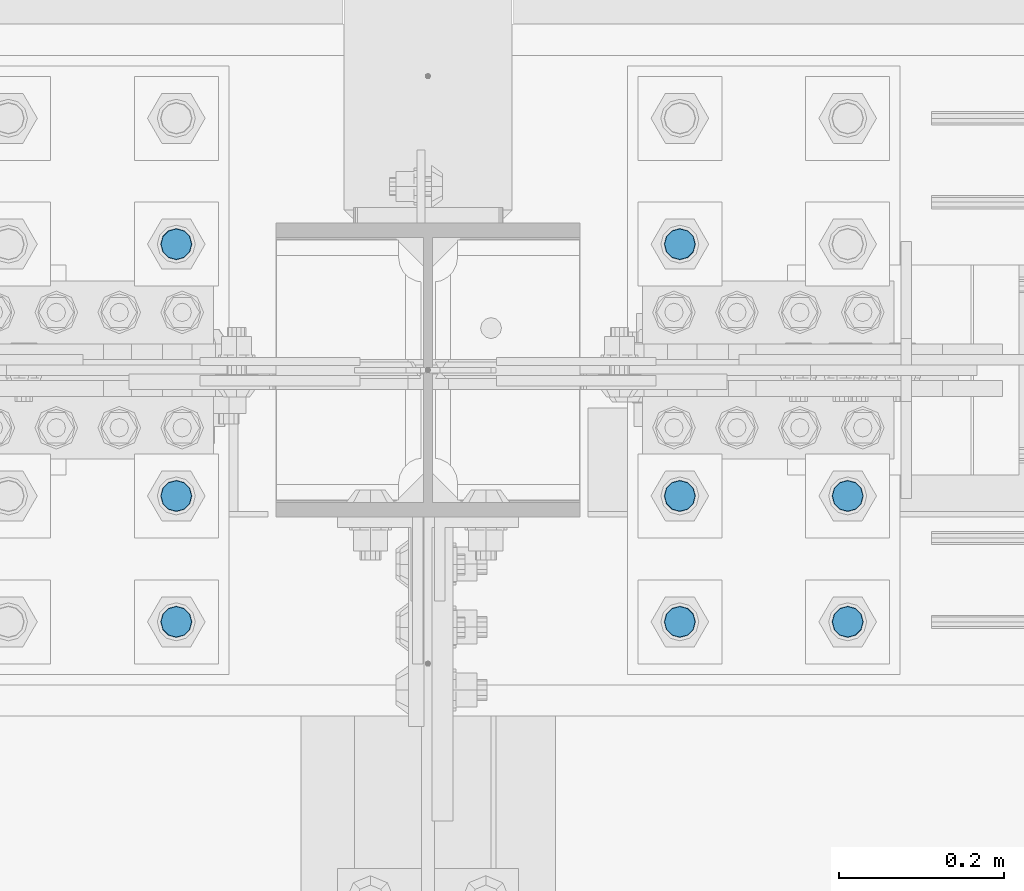
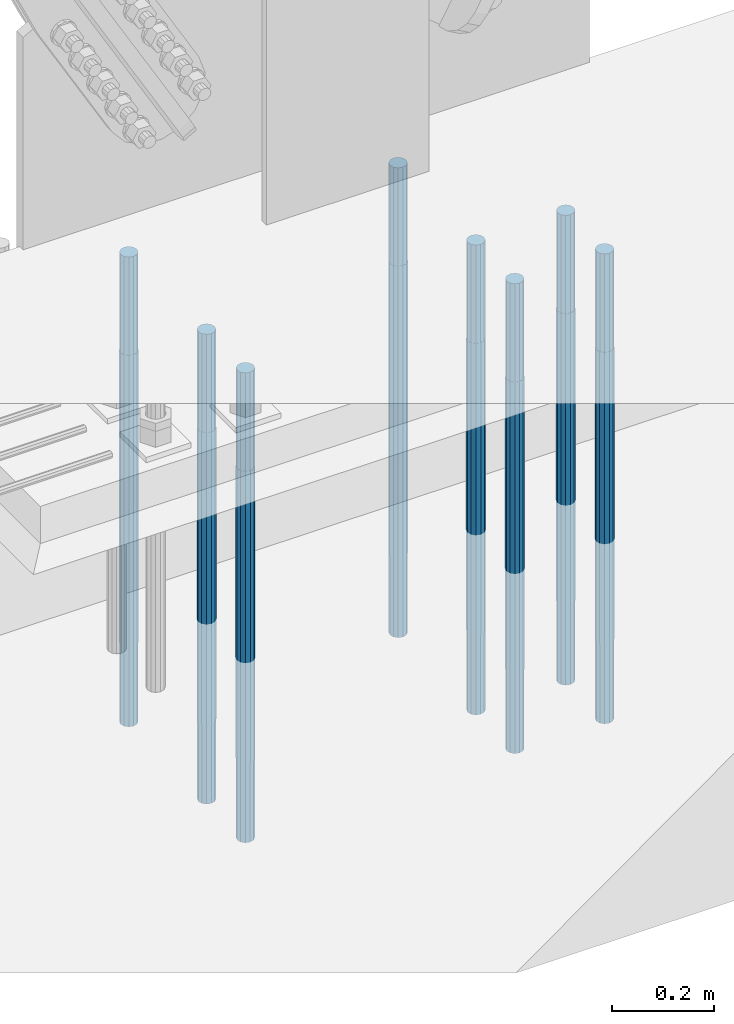
# One storey, part 1382 of 3843: 8 columns, 1 element without a shape of its own.
"""IFC2X3 building model written with IfcOpenShell, lengths in millimetres."""

import ifcopenshell
import ifcopenshell.guid

model = None  # the IFC model being written
_history = None  # IfcOwnerHistory: only IFC2X3 demands one
_inside = {}  # id of a spatial element -> (the spatial element, [elements in it])
_under = {}  # id of a project, library or spatial element -> (it, [spatial elements below it])
_declared = {}  # id of a project -> (the project, [libraries it declares])
_typed = {}  # id of a type object -> (the type object, [elements of that type])
_made_of = {}  # id of a material, layer set ... -> (it, [elements and type objects made of it])


def new_model(schema):
    """Start an empty IFC model of exactly this schema.

    Asked for "IFC4X3", IfcOpenShell would pick the latest addendum, in which some entities
    have other attributes; the version numbers below select the first issue.
    IFC2X3 requires an IfcOwnerHistory on every rooted entity: one is made here for all.
    """
    global model, _history
    if schema == "IFC4X3":
        model = ifcopenshell.file(schema_version=(4, 3, 0, 0))
    else:
        model = ifcopenshell.file(schema=schema)
    _inside.clear()
    _under.clear()
    _declared.clear()
    _typed.clear()
    _made_of.clear()
    _history = None
    if model.schema == "IFC2X3":
        org = make("IfcOrganization", Name="unknown")
        user = make(
            "IfcPersonAndOrganization",
            ThePerson=make("IfcPerson", FamilyName="unknown"),
            TheOrganization=org,
        )
        app = make(
            "IfcApplication",
            ApplicationDeveloper=org,
            Version="unknown",
            ApplicationFullName="unknown",
            ApplicationIdentifier="unknown",
        )
        _history = make(
            "IfcOwnerHistory",
            OwningUser=user,
            OwningApplication=app,
            ChangeAction="ADDED",
            CreationDate=0,
        )
    return model


def make(cls, **values):
    """One entity of the class cls with the attributes given. An attribute that is None is left unset."""
    return model.create_entity(
        cls, **{name: value for name, value in values.items() if value is not None}
    )


def rooted(cls, **values):
    """An entity with a GlobalId (a new one), such as an element, a storey or a relation."""
    return make(cls, GlobalId=ifcopenshell.guid.new(), OwnerHistory=_history, **values)


def si_unit(unit_type, name, prefix=None):
    """IfcSIUnit, for example si_unit("LENGTHUNIT", "METRE", prefix="MILLI")."""
    return make("IfcSIUnit", UnitType=unit_type, Prefix=prefix, Name=name)


def assignment(units):
    """IfcUnitAssignment: the units of a project."""
    return None if units is None else make("IfcUnitAssignment", Units=units)


def point(xyz):
    """IfcCartesianPoint."""
    return None if xyz is None else make("IfcCartesianPoint", Coordinates=xyz)


def direction(xyz):
    """IfcDirection."""
    return None if xyz is None else make("IfcDirection", DirectionRatios=xyz)


def frame(location, z_axis=None, x_axis=None):
    """IfcAxis2Placement3D, a coordinate frame: its origin and axes. An axis left out is left unset."""
    return make(
        "IfcAxis2Placement3D",
        Location=point(location),
        Axis=direction(z_axis),
        RefDirection=direction(x_axis),
    )


def origin_with_axes():
    """The frame at (0, 0, 0) with the z axis (0, 0, 1) and the x axis (1, 0, 0) written out."""
    return frame((0.0, 0.0, 0.0), z_axis=(0.0, 0.0, 1.0), x_axis=(1.0, 0.0, 0.0))


def place(relative_to, where):
    """IfcLocalPlacement: puts the frame where relative to a parent placement (None: the world)."""
    return make(
        "IfcLocalPlacement", PlacementRelTo=relative_to, RelativePlacement=where
    )


def context(
    kind, dimensions, precision=None, world=None, true_north=None, identifier=None
):
    """IfcGeometricRepresentationContext, for example the 3D "Model" context."""
    return make(
        "IfcGeometricRepresentationContext",
        ContextIdentifier=identifier,
        ContextType=kind,
        CoordinateSpaceDimension=dimensions,
        Precision=precision,
        WorldCoordinateSystem=world,
        TrueNorth=true_north,
    )


def subcontext(parent, identifier, kind, view, scale=None):
    """IfcGeometricRepresentationSubContext, for example "Body" below "Model"."""
    return make(
        "IfcGeometricRepresentationSubContext",
        ContextIdentifier=identifier,
        ContextType=kind,
        ParentContext=parent,
        TargetScale=scale,
        TargetView=view,
    )


def project(units=None, contexts=None):
    """IfcProject with its units and contexts."""
    return rooted(
        "IfcProject",
        Name="project",
        RepresentationContexts=contexts,
        UnitsInContext=assignment(units),
    )


def spatial(cls, under=None, at=None, **own):
    """A site, building, storey or space (cls), placed at a placement, below another one or the project."""
    s = rooted(cls, ObjectPlacement=at, **own)
    if under is not None:
        _under.setdefault(under.id(), (under, []))[1].append(s)
    return s


def faces_of(points, faces, orient=None, outer=None):
    """IfcFace entities. A face is a list of loops; a loop is a list of indices into points, from 0.

    orient and outer hold one flag for each loop. By default every Orientation is true, the
    first loop of a face is its IfcFaceOuterBound and the others are IfcFaceBound.
    """
    made = []
    for i, loops in enumerate(faces):
        bounds = []
        for j, loop in enumerate(loops):
            is_outer = j == 0 if outer is None else outer[i][j]
            bounds.append(
                make(
                    "IfcFaceOuterBound" if is_outer else "IfcFaceBound",
                    Bound=make("IfcPolyLoop", Polygon=[points[k] for k in loop]),
                    Orientation=True if orient is None else orient[i][j],
                )
            )
        made.append(make("IfcFace", Bounds=bounds))
    return made


def faceted_brep(points, faces, orient=None, outer=None, voids=None):
    """IfcFacetedBrep: a solid bounded by flat faces; with voids (closed shells), ...WithVoids."""
    shared = [point(p) for p in points]
    hull = make("IfcClosedShell", CfsFaces=faces_of(shared, faces, orient, outer))
    if voids is None:
        return make("IfcFacetedBrep", Outer=hull)
    return make(
        "IfcFacetedBrepWithVoids",
        Outer=hull,
        Voids=[
            make(cls, CfsFaces=faces_of(shared, fs, o, b)) for cls, fs, o, b in voids
        ],
    )


def shape(context_of_items, identifier, shape_type, items):
    """IfcShapeRepresentation: the items that make up one representation, for example the "Body"."""
    return make(
        "IfcShapeRepresentation",
        ContextOfItems=context_of_items,
        RepresentationIdentifier=identifier,
        RepresentationType=shape_type,
        Items=items,
    )


def material(Name=None, Category=None):
    """IfcMaterial."""
    return make("IfcMaterial", Name=Name, Category=Category)


def made_of(thing, what):
    """Note that an element or type object is made of a material, layer set ...; save() writes the relation."""
    if what is not None:
        _made_of.setdefault(what.id(), (what, []))[1].append(thing)
    return thing


def type_object(cls, material=None, **own):
    """A type object (cls), such as IfcWallType, which elements share."""
    return made_of(rooted(cls, **own), material)


def element(
    cls,
    number,
    at=None,
    inside=None,
    cuts=None,
    type_object=None,
    material=None,
    context=None,
    identifier="Body",
    shape_type=None,
    held_by="IfcProductDefinitionShape",
    body=None,
    shapes=None,
    **own,
):
    """One element of the class cls, such as IfcWall. Its Tag is "e" and its number.

    at: its placement. inside: the storey or other place that contains it. cuts: it is an
    opening in that element (IfcRelVoidsElement). A single representation is given by context,
    identifier, shape_type and body (its items); several are given by shapes. held_by: the class
    of the entity that holds the representations. save() writes the other relations.
    """
    e = rooted(cls, Tag="e%d" % number, ObjectPlacement=at, **own)
    if body is not None:
        shapes = [shape(context, identifier, shape_type, body)]
    if shapes is not None:
        e.Representation = make(held_by, Representations=shapes)
    if inside is not None:
        _inside.setdefault(inside.id(), (inside, []))[1].append(e)
    if cuts is not None:
        rooted(
            "IfcRelVoidsElement", RelatingBuildingElement=cuts, RelatedOpeningElement=e
        )
    if type_object is not None:
        _typed.setdefault(type_object.id(), (type_object, []))[1].append(e)
    return made_of(e, material)


def aggregate(whole, parts):
    """IfcRelAggregates: a whole, such as a stair, and the parts it consists of."""
    return rooted("IfcRelAggregates", RelatingObject=whole, RelatedObjects=parts)


def save(model, path):
    """Write the relations noted so far, then the file.

    IfcRelAggregates (storeys below a building ...), IfcRelContainedInSpatialStructure (elements
    in a storey), IfcRelDefinesByType, IfcRelAssociatesMaterial and IfcRelDeclares: one each for
    every whole, place, type object, material and project.
    """
    for whole, parts in _under.values():
        aggregate(whole, parts)
    for where, things in _inside.values():
        rooted(
            "IfcRelContainedInSpatialStructure",
            RelatedElements=things,
            RelatingStructure=where,
        )
    for kind, things in _typed.values():
        rooted("IfcRelDefinesByType", RelatedObjects=things, RelatingType=kind)
    for what, things in _made_of.values():
        rooted("IfcRelAssociatesMaterial", RelatedObjects=things, RelatingMaterial=what)
    for by, libraries in _declared.values():
        rooted("IfcRelDeclares", RelatingContext=by, RelatedDefinitions=libraries)
    model.write(path)


model = new_model("IFC2X3")

# Units and contexts
model_context = context("Model", 3, precision=1e-05, world=origin_with_axes())
body_context = subcontext(model_context, "Body", "Model", "MODEL_VIEW")
ifc_project = project(units=[si_unit("LENGTHUNIT", "METRE", prefix="MILLI"), si_unit("AREAUNIT", "SQUARE_METRE"), si_unit("VOLUMEUNIT", "CUBIC_METRE"), si_unit("MASSUNIT", "GRAM", prefix="KILO"), si_unit("TIMEUNIT", "SECOND"), si_unit("PLANEANGLEUNIT", "RADIAN"), si_unit("SOLIDANGLEUNIT", "STERADIAN"), si_unit("THERMODYNAMICTEMPERATUREUNIT", "DEGREE_CELSIUS"), si_unit("LUMINOUSINTENSITYUNIT", "LUMEN")], contexts=[model_context])

# Site, building, storey
site_placement = place(None, origin_with_axes())
site = spatial("IfcSite", under=ifc_project, at=site_placement, CompositionType="ELEMENT")
building_placement = place(site_placement, origin_with_axes())
building = spatial("IfcBuilding", under=site, at=building_placement, Name="Undefined", CompositionType="ELEMENT")
storey_placement = place(building_placement, origin_with_axes())
storey = spatial("IfcBuildingStorey", under=building, at=storey_placement, Name="Undefined", CompositionType="ELEMENT", Elevation=0.0)

# Assembly, columns
assembly_placement = place(storey_placement, origin_with_axes())
assembly = element("IfcElementAssembly", 1, at=assembly_placement, inside=storey, Name="TEMPLATE", AssemblyPlace="NOTDEFINED", PredefinedType="RIGID_FRAME")
ifc_material = material(Name="Undefined/F1554-GR.55")
column_type = type_object("IfcColumnType", PredefinedType="NOTDEFINED")
column_1_placement = place(assembly_placement, frame((55626.0, 91909.9, 30022.8), z_axis=(0.0, -1.0, 0.0), x_axis=(0.0, 0.0, -1.0)))
column_1 = element("IfcColumn", 2, at=column_1_placement, type_object=column_type, material=ifc_material, Name="ANCHOR_ROD", context=body_context, shape_type="Brep", body=[
    faceted_brep([(-234.950000000001, -16.0214699700155, 9.25), (-234.950000000001, -9.25, 16.0214699700155), (-234.950000000001, 0.0, 18.5), (-234.950000000001, 9.25, 16.0214699700155), (-234.950000000001, 16.0214699700155, 9.25), (-234.950000000001, 18.5, 0.0), (-234.950000000001, 16.0214699700155, -9.25), (-234.950000000001, 9.25, -16.0214699700155), (-234.950000000001, 0.0, -18.5), (-234.950000000001, -9.25, -16.0214699700155), (-234.950000000001, -16.0214699700155, -9.25), (-234.950000000001, -18.5, 0.0), (0.0, 18.5, 0.0), (0.0, 16.0214699700118, -9.25), (0.0, 9.25, -16.0214699700155), (0.0, 0.0, -18.5), (0.0, -9.25, -16.0214699700155), (0.0, -16.0214699700118, -9.25), (0.0, -18.5, 0.0), (0.0, -16.0214699700118, 9.25), (0.0, -9.25, 16.0214699700155), (0.0, 0.0, 18.5), (0.0, 9.25, 16.0214699700155), (0.0, 16.0214699700118, 9.25), (0.0, -16.4977839420972, 9.52500000000146), (0.0, -9.52500000000146, 16.4977839420972), (0.0, 0.0, 19.0499989999989), (0.0, 9.52500000000146, 16.4977839420972), (0.0, 16.4977839420972, 9.52500000000146), (0.0, 19.0500000000029, 0.0), (0.0, 16.4977839420972, -9.52500000000146), (0.0, 9.52500000000146, -16.4977839420972), (0.0, 0.0, -19.0499989999989), (0.0, -9.52500000000146, -16.4977839420972), (0.0, -16.4977839420972, -9.52500000000146), (0.0, -19.0500000000029, 0.0), (698.5, -19.0499999999993, 0.0), (698.5, -16.4977839420935, 9.52499999999418), (698.5, -9.52500000000146, 16.4977839420899), (698.5, 0.0, 19.0500000000029), (698.5, 9.52500000000146, 16.4977839420899), (698.5, 16.4977839420935, 9.52499999999418), (698.5, 19.0499999999993, 0.0), (698.5, 16.4977839420935, -9.52499999999418), (698.5, 9.52500000000146, -16.4977839420899), (698.5, 0.0, -19.0500000000029), (698.5, -9.52500000000146, -16.4977839420899), (698.5, -16.4977839420935, -9.52499999999418), (698.5, -9.25, 16.0214699700155), (698.5, 0.0, 18.5), (698.5, 9.25, 16.0214699700155), (698.5, 16.0214699700118, 9.25), (698.5, 18.5, 0.0), (698.5, 16.0214699700118, -9.25), (698.5, 9.25, -16.0214699700155), (698.5, 0.0, -18.5), (698.5, -9.25, -16.0214699700155), (698.5, -16.0214699700118, -9.25), (698.5, -18.5, 0.0), (698.5, -16.0214699700118, 9.25), (889.0, -9.25, -16.0214699700155), (889.0, 0.0, -18.5), (889.0, 9.25, -16.0214699700155), (889.0, 16.0214699700118, -9.25), (889.0, 18.5, 0.0), (889.0, 16.0214699700118, 9.25), (889.0, 9.25, 16.0214699700155), (889.0, 0.0, 18.5), (889.0, -9.25, 16.0214699700155), (889.0, -16.0214699700118, 9.25), (889.0, -18.5, 0.0), (889.0, -16.0214699700118, -9.25)], [[[0, 1, 2, 3, 4, 5, 6, 7, 8, 9, 10, 11]], [[6, 5, 12, 13]], [[7, 6, 13, 14]], [[8, 7, 14, 15]], [[9, 8, 15, 16]], [[10, 9, 16, 17]], [[11, 10, 17, 18]], [[0, 11, 18, 19]], [[1, 0, 19, 20]], [[2, 1, 20, 21]], [[3, 2, 21, 22]], [[4, 3, 22, 23]], [[5, 4, 23, 12]], [[24, 25, 26, 27, 28, 29, 30, 31, 32, 33, 34, 35], [22, 21, 20, 19, 18, 17, 16, 15, 14, 13, 12, 23]], [[24, 35, 36, 37]], [[25, 24, 37, 38]], [[26, 25, 38, 39]], [[27, 26, 39, 40]], [[28, 27, 40, 41]], [[29, 28, 41, 42]], [[30, 29, 42, 43]], [[31, 30, 43, 44]], [[32, 31, 44, 45]], [[33, 32, 45, 46]], [[34, 33, 46, 47]], [[35, 34, 47, 36]], [[46, 45, 44, 43, 42, 41, 40, 39, 38, 37, 36, 47], [48, 49, 50, 51, 52, 53, 54, 55, 56, 57, 58, 59]], [[60, 61, 62, 63, 64, 65, 66, 67, 68, 69, 70, 71]], [[68, 67, 49, 48]], [[69, 68, 48, 59]], [[70, 69, 59, 58]], [[71, 70, 58, 57]], [[60, 71, 57, 56]], [[61, 60, 56, 55]], [[62, 61, 55, 54]], [[63, 62, 54, 53]], [[64, 63, 53, 52]], [[65, 64, 52, 51]], [[66, 65, 51, 50]], [[67, 66, 50, 49]]]),
])
column_2_placement = place(assembly_placement, frame((56235.6, 91909.9, 30022.8), z_axis=(0.0, 1.0, 0.0), x_axis=(0.0, 0.0, -1.0)))
column_2 = element("IfcColumn", 3, at=column_2_placement, type_object=column_type, material=ifc_material, Name="ANCHOR_ROD", context=body_context, shape_type="Brep", body=[
    faceted_brep([(-234.950000000001, -16.0214699700155, 9.25), (-234.950000000001, -9.25, 16.0214699700155), (-234.950000000001, 0.0, 18.5), (-234.950000000001, 9.25, 16.0214699700155), (-234.950000000001, 16.0214699700155, 9.25), (-234.950000000001, 18.5, 0.0), (-234.950000000001, 16.0214699700155, -9.25), (-234.950000000001, 9.25, -16.0214699700155), (-234.950000000001, 0.0, -18.5), (-234.950000000001, -9.25, -16.0214699700155), (-234.950000000001, -16.0214699700155, -9.25), (-234.950000000001, -18.5, 0.0), (0.0, 18.5, 0.0), (0.0, 16.0214699700118, -9.25), (0.0, 9.25, -16.0214699700155), (0.0, 0.0, -18.5), (0.0, -9.25, -16.0214699700155), (0.0, -16.0214699700118, -9.25), (0.0, -18.5, 0.0), (0.0, -16.0214699700118, 9.25), (0.0, -9.25, 16.0214699700155), (0.0, 0.0, 18.5), (0.0, 9.25, 16.0214699700155), (0.0, 16.0214699700118, 9.25), (0.0, -16.4977839420972, 9.52500000000146), (0.0, -9.52500000000146, 16.4977839420972), (0.0, 0.0, 19.0499989999989), (0.0, 9.52500000000146, 16.4977839420972), (0.0, 16.4977839420972, 9.52500000000146), (0.0, 19.0500000000029, 0.0), (0.0, 16.4977839420972, -9.52500000000146), (0.0, 9.52500000000146, -16.4977839420972), (0.0, 0.0, -19.0499989999989), (0.0, -9.52500000000146, -16.4977839420972), (0.0, -16.4977839420972, -9.52500000000146), (0.0, -19.0500000000029, 0.0), (698.5, -19.0499999999993, 0.0), (698.5, -16.4977839420935, 9.52499999999418), (698.5, -9.52500000000146, 16.4977839420899), (698.5, 0.0, 19.0500000000029), (698.5, 9.52500000000146, 16.4977839420899), (698.5, 16.4977839420935, 9.52499999999418), (698.5, 19.0499999999993, 0.0), (698.5, 16.4977839420935, -9.52499999999418), (698.5, 9.52500000000146, -16.4977839420899), (698.5, 0.0, -19.0500000000029), (698.5, -9.52500000000146, -16.4977839420899), (698.5, -16.4977839420935, -9.52499999999418), (698.5, -9.25, 16.0214699700155), (698.5, 0.0, 18.5), (698.5, 9.25, 16.0214699700155), (698.5, 16.0214699700118, 9.25), (698.5, 18.5, 0.0), (698.5, 16.0214699700118, -9.25), (698.5, 9.25, -16.0214699700155), (698.5, 0.0, -18.5), (698.5, -9.25, -16.0214699700155), (698.5, -16.0214699700118, -9.25), (698.5, -18.5, 0.0), (698.5, -16.0214699700118, 9.25), (889.0, -9.25, -16.0214699700155), (889.0, 0.0, -18.5), (889.0, 9.25, -16.0214699700155), (889.0, 16.0214699700118, -9.25), (889.0, 18.5, 0.0), (889.0, 16.0214699700118, 9.25), (889.0, 9.25, 16.0214699700155), (889.0, 0.0, 18.5), (889.0, -9.25, 16.0214699700155), (889.0, -16.0214699700118, 9.25), (889.0, -18.5, 0.0), (889.0, -16.0214699700118, -9.25)], [[[0, 1, 2, 3, 4, 5, 6, 7, 8, 9, 10, 11]], [[6, 5, 12, 13]], [[7, 6, 13, 14]], [[8, 7, 14, 15]], [[9, 8, 15, 16]], [[10, 9, 16, 17]], [[11, 10, 17, 18]], [[0, 11, 18, 19]], [[1, 0, 19, 20]], [[2, 1, 20, 21]], [[3, 2, 21, 22]], [[4, 3, 22, 23]], [[5, 4, 23, 12]], [[24, 25, 26, 27, 28, 29, 30, 31, 32, 33, 34, 35], [22, 21, 20, 19, 18, 17, 16, 15, 14, 13, 12, 23]], [[24, 35, 36, 37]], [[25, 24, 37, 38]], [[26, 25, 38, 39]], [[27, 26, 39, 40]], [[28, 27, 40, 41]], [[29, 28, 41, 42]], [[30, 29, 42, 43]], [[31, 30, 43, 44]], [[32, 31, 44, 45]], [[33, 32, 45, 46]], [[34, 33, 46, 47]], [[35, 34, 47, 36]], [[46, 45, 44, 43, 42, 41, 40, 39, 38, 37, 36, 47], [48, 49, 50, 51, 52, 53, 54, 55, 56, 57, 58, 59]], [[60, 61, 62, 63, 64, 65, 66, 67, 68, 69, 70, 71]], [[68, 67, 49, 48]], [[69, 68, 48, 59]], [[70, 69, 59, 58]], [[71, 70, 58, 57]], [[60, 71, 57, 56]], [[61, 60, 56, 55]], [[62, 61, 55, 54]], [[63, 62, 54, 53]], [[64, 63, 53, 52]], [[65, 64, 52, 51]], [[66, 65, 51, 50]], [[67, 66, 50, 49]]]),
])
column_3_placement = place(assembly_placement, frame((56438.8, 91909.9, 30022.8), z_axis=(0.0, 1.0, 0.0), x_axis=(0.0, 0.0, -1.0)))
column_3 = element("IfcColumn", 4, at=column_3_placement, type_object=column_type, material=ifc_material, Name="ANCHOR_ROD", context=body_context, shape_type="Brep", body=[
    faceted_brep([(-234.950000000001, -16.0214699700155, 9.25), (-234.950000000001, -9.25, 16.0214699700155), (-234.950000000001, 0.0, 18.5), (-234.950000000001, 9.25, 16.0214699700155), (-234.950000000001, 16.0214699700155, 9.25), (-234.950000000001, 18.5, 0.0), (-234.950000000001, 16.0214699700155, -9.25), (-234.950000000001, 9.25, -16.0214699700155), (-234.950000000001, 0.0, -18.5), (-234.950000000001, -9.25, -16.0214699700155), (-234.950000000001, -16.0214699700155, -9.25), (-234.950000000001, -18.5, 0.0), (0.0, 18.5, 0.0), (0.0, 16.0214699700118, -9.25), (0.0, 9.25, -16.0214699700155), (0.0, 0.0, -18.5), (0.0, -9.25, -16.0214699700155), (0.0, -16.0214699700118, -9.25), (0.0, -18.5, 0.0), (0.0, -16.0214699700118, 9.25), (0.0, -9.25, 16.0214699700155), (0.0, 0.0, 18.5), (0.0, 9.25, 16.0214699700155), (0.0, 16.0214699700118, 9.25), (0.0, -16.4977839420972, 9.52500000000146), (0.0, -9.52500000000146, 16.4977839420972), (0.0, 0.0, 19.0499989999989), (0.0, 9.52500000000146, 16.4977839420972), (0.0, 16.4977839420972, 9.52500000000146), (0.0, 19.0500000000029, 0.0), (0.0, 16.4977839420972, -9.52500000000146), (0.0, 9.52500000000146, -16.4977839420972), (0.0, 0.0, -19.0499989999989), (0.0, -9.52500000000146, -16.4977839420972), (0.0, -16.4977839420972, -9.52500000000146), (0.0, -19.0500000000029, 0.0), (698.5, -19.0499999999993, 0.0), (698.5, -16.4977839420935, 9.52499999999418), (698.5, -9.52500000000146, 16.4977839420899), (698.5, 0.0, 19.0500000000029), (698.5, 9.52500000000146, 16.4977839420899), (698.5, 16.4977839420935, 9.52499999999418), (698.5, 19.0499999999993, 0.0), (698.5, 16.4977839420935, -9.52499999999418), (698.5, 9.52500000000146, -16.4977839420899), (698.5, 0.0, -19.0500000000029), (698.5, -9.52500000000146, -16.4977839420899), (698.5, -16.4977839420935, -9.52499999999418), (698.5, -9.25, 16.0214699700155), (698.5, 0.0, 18.5), (698.5, 9.25, 16.0214699700155), (698.5, 16.0214699700118, 9.25), (698.5, 18.5, 0.0), (698.5, 16.0214699700118, -9.25), (698.5, 9.25, -16.0214699700155), (698.5, 0.0, -18.5), (698.5, -9.25, -16.0214699700155), (698.5, -16.0214699700118, -9.25), (698.5, -18.5, 0.0), (698.5, -16.0214699700118, 9.25), (889.0, -9.25, -16.0214699700155), (889.0, 0.0, -18.5), (889.0, 9.25, -16.0214699700155), (889.0, 16.0214699700118, -9.25), (889.0, 18.5, 0.0), (889.0, 16.0214699700118, 9.25), (889.0, 9.25, 16.0214699700155), (889.0, 0.0, 18.5), (889.0, -9.25, 16.0214699700155), (889.0, -16.0214699700118, 9.25), (889.0, -18.5, 0.0), (889.0, -16.0214699700118, -9.25)], [[[0, 1, 2, 3, 4, 5, 6, 7, 8, 9, 10, 11]], [[6, 5, 12, 13]], [[7, 6, 13, 14]], [[8, 7, 14, 15]], [[9, 8, 15, 16]], [[10, 9, 16, 17]], [[11, 10, 17, 18]], [[0, 11, 18, 19]], [[1, 0, 19, 20]], [[2, 1, 20, 21]], [[3, 2, 21, 22]], [[4, 3, 22, 23]], [[5, 4, 23, 12]], [[24, 25, 26, 27, 28, 29, 30, 31, 32, 33, 34, 35], [22, 21, 20, 19, 18, 17, 16, 15, 14, 13, 12, 23]], [[24, 35, 36, 37]], [[25, 24, 37, 38]], [[26, 25, 38, 39]], [[27, 26, 39, 40]], [[28, 27, 40, 41]], [[29, 28, 41, 42]], [[30, 29, 42, 43]], [[31, 30, 43, 44]], [[32, 31, 44, 45]], [[33, 32, 45, 46]], [[34, 33, 46, 47]], [[35, 34, 47, 36]], [[46, 45, 44, 43, 42, 41, 40, 39, 38, 37, 36, 47], [48, 49, 50, 51, 52, 53, 54, 55, 56, 57, 58, 59]], [[60, 61, 62, 63, 64, 65, 66, 67, 68, 69, 70, 71]], [[68, 67, 49, 48]], [[69, 68, 48, 59]], [[70, 69, 59, 58]], [[71, 70, 58, 57]], [[60, 71, 57, 56]], [[61, 60, 56, 55]], [[62, 61, 55, 54]], [[63, 62, 54, 53]], [[64, 63, 53, 52]], [[65, 64, 52, 51]], [[66, 65, 51, 50]], [[67, 66, 50, 49]]]),
])
column_4_placement = place(assembly_placement, frame((55626.0, 92062.3, 30022.8), z_axis=(0.0, -1.0, 0.0), x_axis=(0.0, 0.0, -1.0)))
column_4 = element("IfcColumn", 5, at=column_4_placement, type_object=column_type, material=ifc_material, Name="ANCHOR_ROD", context=body_context, shape_type="Brep", body=[
    faceted_brep([(-234.950000000001, -16.0214699700155, 9.25), (-234.950000000001, -9.25, 16.0214699700155), (-234.950000000001, 0.0, 18.5), (-234.950000000001, 9.25, 16.0214699700155), (-234.950000000001, 16.0214699700155, 9.25), (-234.950000000001, 18.5, 0.0), (-234.950000000001, 16.0214699700155, -9.25), (-234.950000000001, 9.25, -16.0214699700155), (-234.950000000001, 0.0, -18.5), (-234.950000000001, -9.25, -16.0214699700155), (-234.950000000001, -16.0214699700155, -9.25), (-234.950000000001, -18.5, 0.0), (0.0, 18.5, 0.0), (0.0, 16.0214699700118, -9.25), (0.0, 9.25, -16.0214699700155), (0.0, 0.0, -18.5), (0.0, -9.25, -16.0214699700155), (0.0, -16.0214699700118, -9.25), (0.0, -18.5, 0.0), (0.0, -16.0214699700118, 9.25), (0.0, -9.25, 16.0214699700155), (0.0, 0.0, 18.5), (0.0, 9.25, 16.0214699700155), (0.0, 16.0214699700118, 9.25), (0.0, -16.4977839420972, 9.52500000000146), (0.0, -9.52500000000146, 16.4977839420972), (0.0, 0.0, 19.0499989999989), (0.0, 9.52500000000146, 16.4977839420972), (0.0, 16.4977839420972, 9.52500000000146), (0.0, 19.0500000000029, 0.0), (0.0, 16.4977839420972, -9.52500000000146), (0.0, 9.52500000000146, -16.4977839420972), (0.0, 0.0, -19.0499989999989), (0.0, -9.52500000000146, -16.4977839420972), (0.0, -16.4977839420972, -9.52500000000146), (0.0, -19.0500000000029, 0.0), (698.5, -19.0499999999993, 0.0), (698.5, -16.4977839420935, 9.52499999999418), (698.5, -9.52500000000146, 16.4977839420899), (698.5, 0.0, 19.0500000000029), (698.5, 9.52500000000146, 16.4977839420899), (698.5, 16.4977839420935, 9.52499999999418), (698.5, 19.0499999999993, 0.0), (698.5, 16.4977839420935, -9.52499999999418), (698.5, 9.52500000000146, -16.4977839420899), (698.5, 0.0, -19.0500000000029), (698.5, -9.52500000000146, -16.4977839420899), (698.5, -16.4977839420935, -9.52499999999418), (698.5, -9.25, 16.0214699700155), (698.5, 0.0, 18.5), (698.5, 9.25, 16.0214699700155), (698.5, 16.0214699700118, 9.25), (698.5, 18.5, 0.0), (698.5, 16.0214699700118, -9.25), (698.5, 9.25, -16.0214699700155), (698.5, 0.0, -18.5), (698.5, -9.25, -16.0214699700155), (698.5, -16.0214699700118, -9.25), (698.5, -18.5, 0.0), (698.5, -16.0214699700118, 9.25), (889.0, -9.25, -16.0214699700155), (889.0, 0.0, -18.5), (889.0, 9.25, -16.0214699700155), (889.0, 16.0214699700118, -9.25), (889.0, 18.5, 0.0), (889.0, 16.0214699700118, 9.25), (889.0, 9.25, 16.0214699700155), (889.0, 0.0, 18.5), (889.0, -9.25, 16.0214699700155), (889.0, -16.0214699700118, 9.25), (889.0, -18.5, 0.0), (889.0, -16.0214699700118, -9.25)], [[[0, 1, 2, 3, 4, 5, 6, 7, 8, 9, 10, 11]], [[6, 5, 12, 13]], [[7, 6, 13, 14]], [[8, 7, 14, 15]], [[9, 8, 15, 16]], [[10, 9, 16, 17]], [[11, 10, 17, 18]], [[0, 11, 18, 19]], [[1, 0, 19, 20]], [[2, 1, 20, 21]], [[3, 2, 21, 22]], [[4, 3, 22, 23]], [[5, 4, 23, 12]], [[24, 25, 26, 27, 28, 29, 30, 31, 32, 33, 34, 35], [22, 21, 20, 19, 18, 17, 16, 15, 14, 13, 12, 23]], [[24, 35, 36, 37]], [[25, 24, 37, 38]], [[26, 25, 38, 39]], [[27, 26, 39, 40]], [[28, 27, 40, 41]], [[29, 28, 41, 42]], [[30, 29, 42, 43]], [[31, 30, 43, 44]], [[32, 31, 44, 45]], [[33, 32, 45, 46]], [[34, 33, 46, 47]], [[35, 34, 47, 36]], [[46, 45, 44, 43, 42, 41, 40, 39, 38, 37, 36, 47], [48, 49, 50, 51, 52, 53, 54, 55, 56, 57, 58, 59]], [[60, 61, 62, 63, 64, 65, 66, 67, 68, 69, 70, 71]], [[68, 67, 49, 48]], [[69, 68, 48, 59]], [[70, 69, 59, 58]], [[71, 70, 58, 57]], [[60, 71, 57, 56]], [[61, 60, 56, 55]], [[62, 61, 55, 54]], [[63, 62, 54, 53]], [[64, 63, 53, 52]], [[65, 64, 52, 51]], [[66, 65, 51, 50]], [[67, 66, 50, 49]]]),
])
column_5_placement = place(assembly_placement, frame((56235.6, 92062.3, 30022.8), z_axis=(0.0, 1.0, 0.0), x_axis=(0.0, 0.0, -1.0)))
column_5 = element("IfcColumn", 6, at=column_5_placement, type_object=column_type, material=ifc_material, Name="ANCHOR_ROD", context=body_context, shape_type="Brep", body=[
    faceted_brep([(-234.950000000001, -16.0214699700155, 9.25), (-234.950000000001, -9.25, 16.0214699700155), (-234.950000000001, 0.0, 18.5), (-234.950000000001, 9.25, 16.0214699700155), (-234.950000000001, 16.0214699700155, 9.25), (-234.950000000001, 18.5, 0.0), (-234.950000000001, 16.0214699700155, -9.25), (-234.950000000001, 9.25, -16.0214699700155), (-234.950000000001, 0.0, -18.5), (-234.950000000001, -9.25, -16.0214699700155), (-234.950000000001, -16.0214699700155, -9.25), (-234.950000000001, -18.5, 0.0), (0.0, 18.5, 0.0), (0.0, 16.0214699700118, -9.25), (0.0, 9.25, -16.0214699700155), (0.0, 0.0, -18.5), (0.0, -9.25, -16.0214699700155), (0.0, -16.0214699700118, -9.25), (0.0, -18.5, 0.0), (0.0, -16.0214699700118, 9.25), (0.0, -9.25, 16.0214699700155), (0.0, 0.0, 18.5), (0.0, 9.25, 16.0214699700155), (0.0, 16.0214699700118, 9.25), (0.0, -16.4977839420972, 9.52500000000146), (0.0, -9.52500000000146, 16.4977839420972), (0.0, 0.0, 19.0499989999989), (0.0, 9.52500000000146, 16.4977839420972), (0.0, 16.4977839420972, 9.52500000000146), (0.0, 19.0500000000029, 0.0), (0.0, 16.4977839420972, -9.52500000000146), (0.0, 9.52500000000146, -16.4977839420972), (0.0, 0.0, -19.0499989999989), (0.0, -9.52500000000146, -16.4977839420972), (0.0, -16.4977839420972, -9.52500000000146), (0.0, -19.0500000000029, 0.0), (698.5, -19.0499999999993, 0.0), (698.5, -16.4977839420935, 9.52499999999418), (698.5, -9.52500000000146, 16.4977839420899), (698.5, 0.0, 19.0500000000029), (698.5, 9.52500000000146, 16.4977839420899), (698.5, 16.4977839420935, 9.52499999999418), (698.5, 19.0499999999993, 0.0), (698.5, 16.4977839420935, -9.52499999999418), (698.5, 9.52500000000146, -16.4977839420899), (698.5, 0.0, -19.0500000000029), (698.5, -9.52500000000146, -16.4977839420899), (698.5, -16.4977839420935, -9.52499999999418), (698.5, -9.25, 16.0214699700155), (698.5, 0.0, 18.5), (698.5, 9.25, 16.0214699700155), (698.5, 16.0214699700118, 9.25), (698.5, 18.5, 0.0), (698.5, 16.0214699700118, -9.25), (698.5, 9.25, -16.0214699700155), (698.5, 0.0, -18.5), (698.5, -9.25, -16.0214699700155), (698.5, -16.0214699700118, -9.25), (698.5, -18.5, 0.0), (698.5, -16.0214699700118, 9.25), (889.0, -9.25, -16.0214699700155), (889.0, 0.0, -18.5), (889.0, 9.25, -16.0214699700155), (889.0, 16.0214699700118, -9.25), (889.0, 18.5, 0.0), (889.0, 16.0214699700118, 9.25), (889.0, 9.25, 16.0214699700155), (889.0, 0.0, 18.5), (889.0, -9.25, 16.0214699700155), (889.0, -16.0214699700118, 9.25), (889.0, -18.5, 0.0), (889.0, -16.0214699700118, -9.25)], [[[0, 1, 2, 3, 4, 5, 6, 7, 8, 9, 10, 11]], [[6, 5, 12, 13]], [[7, 6, 13, 14]], [[8, 7, 14, 15]], [[9, 8, 15, 16]], [[10, 9, 16, 17]], [[11, 10, 17, 18]], [[0, 11, 18, 19]], [[1, 0, 19, 20]], [[2, 1, 20, 21]], [[3, 2, 21, 22]], [[4, 3, 22, 23]], [[5, 4, 23, 12]], [[24, 25, 26, 27, 28, 29, 30, 31, 32, 33, 34, 35], [22, 21, 20, 19, 18, 17, 16, 15, 14, 13, 12, 23]], [[24, 35, 36, 37]], [[25, 24, 37, 38]], [[26, 25, 38, 39]], [[27, 26, 39, 40]], [[28, 27, 40, 41]], [[29, 28, 41, 42]], [[30, 29, 42, 43]], [[31, 30, 43, 44]], [[32, 31, 44, 45]], [[33, 32, 45, 46]], [[34, 33, 46, 47]], [[35, 34, 47, 36]], [[46, 45, 44, 43, 42, 41, 40, 39, 38, 37, 36, 47], [48, 49, 50, 51, 52, 53, 54, 55, 56, 57, 58, 59]], [[60, 61, 62, 63, 64, 65, 66, 67, 68, 69, 70, 71]], [[68, 67, 49, 48]], [[69, 68, 48, 59]], [[70, 69, 59, 58]], [[71, 70, 58, 57]], [[60, 71, 57, 56]], [[61, 60, 56, 55]], [[62, 61, 55, 54]], [[63, 62, 54, 53]], [[64, 63, 53, 52]], [[65, 64, 52, 51]], [[66, 65, 51, 50]], [[67, 66, 50, 49]]]),
])
column_6_placement = place(assembly_placement, frame((56438.8, 92062.3, 30022.8), z_axis=(0.0, 1.0, 0.0), x_axis=(0.0, 0.0, -1.0)))
column_6 = element("IfcColumn", 7, at=column_6_placement, type_object=column_type, material=ifc_material, Name="ANCHOR_ROD", context=body_context, shape_type="Brep", body=[
    faceted_brep([(-234.950000000001, -16.0214699700155, 9.25), (-234.950000000001, -9.25, 16.0214699700155), (-234.950000000001, 0.0, 18.5), (-234.950000000001, 9.25, 16.0214699700155), (-234.950000000001, 16.0214699700155, 9.25), (-234.950000000001, 18.5, 0.0), (-234.950000000001, 16.0214699700155, -9.25), (-234.950000000001, 9.25, -16.0214699700155), (-234.950000000001, 0.0, -18.5), (-234.950000000001, -9.25, -16.0214699700155), (-234.950000000001, -16.0214699700155, -9.25), (-234.950000000001, -18.5, 0.0), (0.0, 18.5, 0.0), (0.0, 16.0214699700118, -9.25), (0.0, 9.25, -16.0214699700155), (0.0, 0.0, -18.5), (0.0, -9.25, -16.0214699700155), (0.0, -16.0214699700118, -9.25), (0.0, -18.5, 0.0), (0.0, -16.0214699700118, 9.25), (0.0, -9.25, 16.0214699700155), (0.0, 0.0, 18.5), (0.0, 9.25, 16.0214699700155), (0.0, 16.0214699700118, 9.25), (0.0, -16.4977839420972, 9.52500000000146), (0.0, -9.52500000000146, 16.4977839420972), (0.0, 0.0, 19.0499989999989), (0.0, 9.52500000000146, 16.4977839420972), (0.0, 16.4977839420972, 9.52500000000146), (0.0, 19.0500000000029, 0.0), (0.0, 16.4977839420972, -9.52500000000146), (0.0, 9.52500000000146, -16.4977839420972), (0.0, 0.0, -19.0499989999989), (0.0, -9.52500000000146, -16.4977839420972), (0.0, -16.4977839420972, -9.52500000000146), (0.0, -19.0500000000029, 0.0), (698.5, -19.0499999999993, 0.0), (698.5, -16.4977839420935, 9.52499999999418), (698.5, -9.52500000000146, 16.4977839420899), (698.5, 0.0, 19.0500000000029), (698.5, 9.52500000000146, 16.4977839420899), (698.5, 16.4977839420935, 9.52499999999418), (698.5, 19.0499999999993, 0.0), (698.5, 16.4977839420935, -9.52499999999418), (698.5, 9.52500000000146, -16.4977839420899), (698.5, 0.0, -19.0500000000029), (698.5, -9.52500000000146, -16.4977839420899), (698.5, -16.4977839420935, -9.52499999999418), (698.5, -9.25, 16.0214699700155), (698.5, 0.0, 18.5), (698.5, 9.25, 16.0214699700155), (698.5, 16.0214699700118, 9.25), (698.5, 18.5, 0.0), (698.5, 16.0214699700118, -9.25), (698.5, 9.25, -16.0214699700155), (698.5, 0.0, -18.5), (698.5, -9.25, -16.0214699700155), (698.5, -16.0214699700118, -9.25), (698.5, -18.5, 0.0), (698.5, -16.0214699700118, 9.25), (889.0, -9.25, -16.0214699700155), (889.0, 0.0, -18.5), (889.0, 9.25, -16.0214699700155), (889.0, 16.0214699700118, -9.25), (889.0, 18.5, 0.0), (889.0, 16.0214699700118, 9.25), (889.0, 9.25, 16.0214699700155), (889.0, 0.0, 18.5), (889.0, -9.25, 16.0214699700155), (889.0, -16.0214699700118, 9.25), (889.0, -18.5, 0.0), (889.0, -16.0214699700118, -9.25)], [[[0, 1, 2, 3, 4, 5, 6, 7, 8, 9, 10, 11]], [[6, 5, 12, 13]], [[7, 6, 13, 14]], [[8, 7, 14, 15]], [[9, 8, 15, 16]], [[10, 9, 16, 17]], [[11, 10, 17, 18]], [[0, 11, 18, 19]], [[1, 0, 19, 20]], [[2, 1, 20, 21]], [[3, 2, 21, 22]], [[4, 3, 22, 23]], [[5, 4, 23, 12]], [[24, 25, 26, 27, 28, 29, 30, 31, 32, 33, 34, 35], [22, 21, 20, 19, 18, 17, 16, 15, 14, 13, 12, 23]], [[24, 35, 36, 37]], [[25, 24, 37, 38]], [[26, 25, 38, 39]], [[27, 26, 39, 40]], [[28, 27, 40, 41]], [[29, 28, 41, 42]], [[30, 29, 42, 43]], [[31, 30, 43, 44]], [[32, 31, 44, 45]], [[33, 32, 45, 46]], [[34, 33, 46, 47]], [[35, 34, 47, 36]], [[46, 45, 44, 43, 42, 41, 40, 39, 38, 37, 36, 47], [48, 49, 50, 51, 52, 53, 54, 55, 56, 57, 58, 59]], [[60, 61, 62, 63, 64, 65, 66, 67, 68, 69, 70, 71]], [[68, 67, 49, 48]], [[69, 68, 48, 59]], [[70, 69, 59, 58]], [[71, 70, 58, 57]], [[60, 71, 57, 56]], [[61, 60, 56, 55]], [[62, 61, 55, 54]], [[63, 62, 54, 53]], [[64, 63, 53, 52]], [[65, 64, 52, 51]], [[66, 65, 51, 50]], [[67, 66, 50, 49]]]),
])
column_7_placement = place(assembly_placement, frame((55626.0, 92367.1, 30022.8), z_axis=(0.0, -1.0, 0.0), x_axis=(0.0, 0.0, -1.0)))
column_7 = element("IfcColumn", 8, at=column_7_placement, type_object=column_type, material=ifc_material, Name="ANCHOR_ROD", context=body_context, shape_type="Brep", body=[
    faceted_brep([(-234.950000000001, -16.0214699700155, 9.25), (-234.950000000001, -9.25, 16.0214699700155), (-234.950000000001, 0.0, 18.5), (-234.950000000001, 9.25, 16.0214699700155), (-234.950000000001, 16.0214699700155, 9.25), (-234.950000000001, 18.5, 0.0), (-234.950000000001, 16.0214699700155, -9.25), (-234.950000000001, 9.25, -16.0214699700155), (-234.950000000001, 0.0, -18.5), (-234.950000000001, -9.25, -16.0214699700155), (-234.950000000001, -16.0214699700155, -9.25), (-234.950000000001, -18.5, 0.0), (0.0, 18.5, 0.0), (0.0, 16.0214699700118, -9.25), (0.0, 9.25, -16.0214699700155), (0.0, 0.0, -18.5), (0.0, -9.25, -16.0214699700155), (0.0, -16.0214699700118, -9.25), (0.0, -18.5, 0.0), (0.0, -16.0214699700118, 9.25), (0.0, -9.25, 16.0214699700155), (0.0, 0.0, 18.5), (0.0, 9.25, 16.0214699700155), (0.0, 16.0214699700118, 9.25), (0.0, -16.4977839420972, 9.52500000000146), (0.0, -9.52500000000146, 16.4977839420972), (0.0, 0.0, 19.0499989999989), (0.0, 9.52500000000146, 16.4977839420972), (0.0, 16.4977839420972, 9.52500000000146), (0.0, 19.0500000000029, 0.0), (0.0, 16.4977839420972, -9.52500000000146), (0.0, 9.52500000000146, -16.4977839420972), (0.0, 0.0, -19.0499989999989), (0.0, -9.52500000000146, -16.4977839420972), (0.0, -16.4977839420972, -9.52500000000146), (0.0, -19.0500000000029, 0.0), (698.5, -19.0499999999993, 0.0), (698.5, -16.4977839420935, 9.52499999999418), (698.5, -9.52500000000146, 16.4977839420899), (698.5, 0.0, 19.0500000000029), (698.5, 9.52500000000146, 16.4977839420899), (698.5, 16.4977839420935, 9.52499999999418), (698.5, 19.0499999999993, 0.0), (698.5, 16.4977839420935, -9.52499999999418), (698.5, 9.52500000000146, -16.4977839420899), (698.5, 0.0, -19.0500000000029), (698.5, -9.52500000000146, -16.4977839420899), (698.5, -16.4977839420935, -9.52499999999418), (698.5, -9.25, 16.0214699700155), (698.5, 0.0, 18.5), (698.5, 9.25, 16.0214699700155), (698.5, 16.0214699700118, 9.25), (698.5, 18.5, 0.0), (698.5, 16.0214699700118, -9.25), (698.5, 9.25, -16.0214699700155), (698.5, 0.0, -18.5), (698.5, -9.25, -16.0214699700155), (698.5, -16.0214699700118, -9.25), (698.5, -18.5, 0.0), (698.5, -16.0214699700118, 9.25), (889.0, -9.25, -16.0214699700155), (889.0, 0.0, -18.5), (889.0, 9.25, -16.0214699700155), (889.0, 16.0214699700118, -9.25), (889.0, 18.5, 0.0), (889.0, 16.0214699700118, 9.25), (889.0, 9.25, 16.0214699700155), (889.0, 0.0, 18.5), (889.0, -9.25, 16.0214699700155), (889.0, -16.0214699700118, 9.25), (889.0, -18.5, 0.0), (889.0, -16.0214699700118, -9.25)], [[[0, 1, 2, 3, 4, 5, 6, 7, 8, 9, 10, 11]], [[6, 5, 12, 13]], [[7, 6, 13, 14]], [[8, 7, 14, 15]], [[9, 8, 15, 16]], [[10, 9, 16, 17]], [[11, 10, 17, 18]], [[0, 11, 18, 19]], [[1, 0, 19, 20]], [[2, 1, 20, 21]], [[3, 2, 21, 22]], [[4, 3, 22, 23]], [[5, 4, 23, 12]], [[24, 25, 26, 27, 28, 29, 30, 31, 32, 33, 34, 35], [22, 21, 20, 19, 18, 17, 16, 15, 14, 13, 12, 23]], [[24, 35, 36, 37]], [[25, 24, 37, 38]], [[26, 25, 38, 39]], [[27, 26, 39, 40]], [[28, 27, 40, 41]], [[29, 28, 41, 42]], [[30, 29, 42, 43]], [[31, 30, 43, 44]], [[32, 31, 44, 45]], [[33, 32, 45, 46]], [[34, 33, 46, 47]], [[35, 34, 47, 36]], [[46, 45, 44, 43, 42, 41, 40, 39, 38, 37, 36, 47], [48, 49, 50, 51, 52, 53, 54, 55, 56, 57, 58, 59]], [[60, 61, 62, 63, 64, 65, 66, 67, 68, 69, 70, 71]], [[68, 67, 49, 48]], [[69, 68, 48, 59]], [[70, 69, 59, 58]], [[71, 70, 58, 57]], [[60, 71, 57, 56]], [[61, 60, 56, 55]], [[62, 61, 55, 54]], [[63, 62, 54, 53]], [[64, 63, 53, 52]], [[65, 64, 52, 51]], [[66, 65, 51, 50]], [[67, 66, 50, 49]]]),
])
column_8_placement = place(assembly_placement, frame((56235.6, 92367.1, 30022.8), z_axis=(0.0, 1.0, 0.0), x_axis=(0.0, 0.0, -1.0)))
column_8 = element("IfcColumn", 9, at=column_8_placement, type_object=column_type, material=ifc_material, Name="ANCHOR_ROD", context=body_context, shape_type="Brep", body=[
    faceted_brep([(-234.950000000001, -16.0214699700155, 9.25), (-234.950000000001, -9.25, 16.0214699700155), (-234.950000000001, 0.0, 18.5), (-234.950000000001, 9.25, 16.0214699700155), (-234.950000000001, 16.0214699700155, 9.25), (-234.950000000001, 18.5, 0.0), (-234.950000000001, 16.0214699700155, -9.25), (-234.950000000001, 9.25, -16.0214699700155), (-234.950000000001, 0.0, -18.5), (-234.950000000001, -9.25, -16.0214699700155), (-234.950000000001, -16.0214699700155, -9.25), (-234.950000000001, -18.5, 0.0), (0.0, 18.5, 0.0), (0.0, 16.0214699700118, -9.25), (0.0, 9.25, -16.0214699700155), (0.0, 0.0, -18.5), (0.0, -9.25, -16.0214699700155), (0.0, -16.0214699700118, -9.25), (0.0, -18.5, 0.0), (0.0, -16.0214699700118, 9.25), (0.0, -9.25, 16.0214699700155), (0.0, 0.0, 18.5), (0.0, 9.25, 16.0214699700155), (0.0, 16.0214699700118, 9.25), (0.0, -16.4977839420972, 9.52500000000146), (0.0, -9.52500000000146, 16.4977839420972), (0.0, 0.0, 19.0499989999989), (0.0, 9.52500000000146, 16.4977839420972), (0.0, 16.4977839420972, 9.52500000000146), (0.0, 19.0500000000029, 0.0), (0.0, 16.4977839420972, -9.52500000000146), (0.0, 9.52500000000146, -16.4977839420972), (0.0, 0.0, -19.0499989999989), (0.0, -9.52500000000146, -16.4977839420972), (0.0, -16.4977839420972, -9.52500000000146), (0.0, -19.0500000000029, 0.0), (698.5, -19.0499999999993, 0.0), (698.5, -16.4977839420935, 9.52499999999418), (698.5, -9.52500000000146, 16.4977839420899), (698.5, 0.0, 19.0500000000029), (698.5, 9.52500000000146, 16.4977839420899), (698.5, 16.4977839420935, 9.52499999999418), (698.5, 19.0499999999993, 0.0), (698.5, 16.4977839420935, -9.52499999999418), (698.5, 9.52500000000146, -16.4977839420899), (698.5, 0.0, -19.0500000000029), (698.5, -9.52500000000146, -16.4977839420899), (698.5, -16.4977839420935, -9.52499999999418), (698.5, -9.25, 16.0214699700155), (698.5, 0.0, 18.5), (698.5, 9.25, 16.0214699700155), (698.5, 16.0214699700118, 9.25), (698.5, 18.5, 0.0), (698.5, 16.0214699700118, -9.25), (698.5, 9.25, -16.0214699700155), (698.5, 0.0, -18.5), (698.5, -9.25, -16.0214699700155), (698.5, -16.0214699700118, -9.25), (698.5, -18.5, 0.0), (698.5, -16.0214699700118, 9.25), (889.0, -9.25, -16.0214699700155), (889.0, 0.0, -18.5), (889.0, 9.25, -16.0214699700155), (889.0, 16.0214699700118, -9.25), (889.0, 18.5, 0.0), (889.0, 16.0214699700118, 9.25), (889.0, 9.25, 16.0214699700155), (889.0, 0.0, 18.5), (889.0, -9.25, 16.0214699700155), (889.0, -16.0214699700118, 9.25), (889.0, -18.5, 0.0), (889.0, -16.0214699700118, -9.25)], [[[0, 1, 2, 3, 4, 5, 6, 7, 8, 9, 10, 11]], [[6, 5, 12, 13]], [[7, 6, 13, 14]], [[8, 7, 14, 15]], [[9, 8, 15, 16]], [[10, 9, 16, 17]], [[11, 10, 17, 18]], [[0, 11, 18, 19]], [[1, 0, 19, 20]], [[2, 1, 20, 21]], [[3, 2, 21, 22]], [[4, 3, 22, 23]], [[5, 4, 23, 12]], [[24, 25, 26, 27, 28, 29, 30, 31, 32, 33, 34, 35], [22, 21, 20, 19, 18, 17, 16, 15, 14, 13, 12, 23]], [[24, 35, 36, 37]], [[25, 24, 37, 38]], [[26, 25, 38, 39]], [[27, 26, 39, 40]], [[28, 27, 40, 41]], [[29, 28, 41, 42]], [[30, 29, 42, 43]], [[31, 30, 43, 44]], [[32, 31, 44, 45]], [[33, 32, 45, 46]], [[34, 33, 46, 47]], [[35, 34, 47, 36]], [[46, 45, 44, 43, 42, 41, 40, 39, 38, 37, 36, 47], [48, 49, 50, 51, 52, 53, 54, 55, 56, 57, 58, 59]], [[60, 61, 62, 63, 64, 65, 66, 67, 68, 69, 70, 71]], [[68, 67, 49, 48]], [[69, 68, 48, 59]], [[70, 69, 59, 58]], [[71, 70, 58, 57]], [[60, 71, 57, 56]], [[61, 60, 56, 55]], [[62, 61, 55, 54]], [[63, 62, 54, 53]], [[64, 63, 53, 52]], [[65, 64, 52, 51]], [[66, 65, 51, 50]], [[67, 66, 50, 49]]]),
])
aggregate(assembly, [column_1, column_2, column_3, column_4, column_5, column_6, column_7, column_8])

save(model, "model.ifc")
